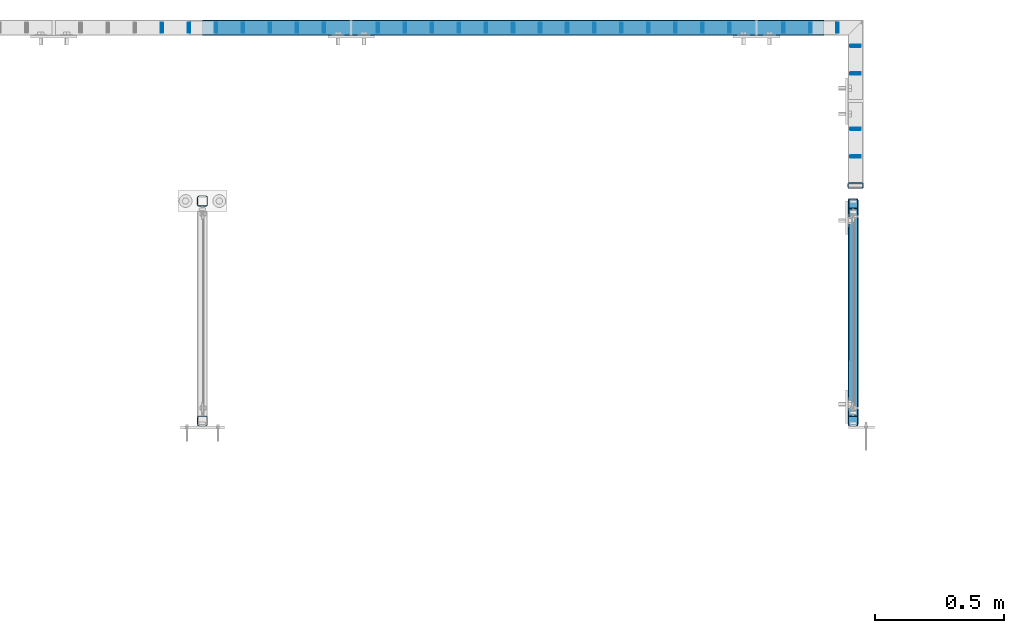
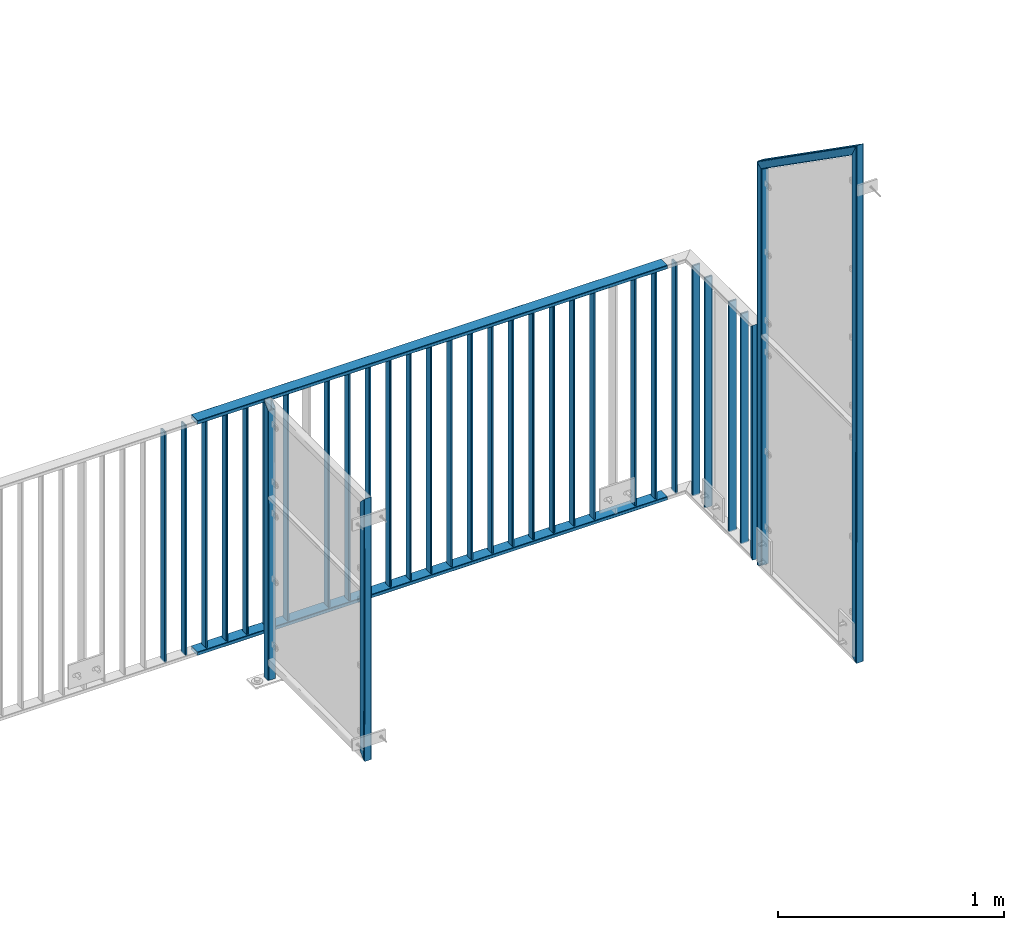
# One storey, part 24 of 156: 36 beams, 5 elements without a shape of their own.
"""IFC2X3 building model written with IfcOpenShell, lengths in millimetres."""

from ifc_helpers import new_model, si_unit, frame, origin_with_axes, origin_2d_with_axis, place, context, subcontext, project, spatial, hollow_rectangle, extrude, clip, halfspace, material, type_object, element, aggregate, save


model = new_model("IFC2X3")

# Units and contexts
model_context = context("Model", 3, precision=1e-05, world=origin_with_axes())
body_context = subcontext(model_context, "Body", "Model", "MODEL_VIEW")
ifc_project = project(units=[si_unit("LENGTHUNIT", "METRE", prefix="MILLI"), si_unit("AREAUNIT", "SQUARE_METRE"), si_unit("VOLUMEUNIT", "CUBIC_METRE"), si_unit("MASSUNIT", "GRAM", prefix="KILO"), si_unit("TIMEUNIT", "SECOND"), si_unit("PLANEANGLEUNIT", "RADIAN"), si_unit("SOLIDANGLEUNIT", "STERADIAN"), si_unit("THERMODYNAMICTEMPERATUREUNIT", "DEGREE_CELSIUS"), si_unit("LUMINOUSINTENSITYUNIT", "LUMEN")], contexts=[model_context])

# Site, building, storey
site_placement = place(None, origin_with_axes())
site = spatial("IfcSite", under=ifc_project, at=site_placement, CompositionType="ELEMENT")
building_placement = place(site_placement, origin_with_axes())
building = spatial("IfcBuilding", under=site, at=building_placement, Name="Undefined", CompositionType="ELEMENT")
storey_placement = place(building_placement, origin_with_axes())
storey = spatial("IfcBuildingStorey", under=building, at=storey_placement, Name="Undefined", CompositionType="ELEMENT", Elevation=0.0)

# Assembly, beam
assembly_1_placement = place(storey_placement, origin_with_axes())
assembly_1 = element("IfcElementAssembly", 1, at=assembly_1_placement, inside=storey, AssemblyPlace="NOTDEFINED", PredefinedType="RIGID_FRAME")
ifc_material = material(Name="STEEL/S235JR")
beam_type_1 = type_object("IfcBeamType", Name="K60/20/2", PredefinedType="NOTDEFINED")
beam_1_placement = place(assembly_1_placement, frame((26802.6741455078, 24057.9916132584, 2740.0), z_axis=(0.0, -1.0, 0.0), x_axis=(-1.0, 0.0, 0.0)))
beam_1 = element("IfcBeam", 2, at=beam_1_placement, type_object=beam_type_1, material=ifc_material, ObjectType="K60/20/2", context=body_context, shape_type="SweptSolid", body=[
    extrude(hollow_rectangle(XDim=20.0, YDim=60.0, WallThickness=2.0, InnerFilletRadius=2.0, OuterFilletRadius=4.0, at=origin_2d_with_axis()), frame((2402.72054931641, 0.0, 0.0), z_axis=(-1.0, 0.0, 0.0), x_axis=(0.0, -1.0, 0.0)), (0.0, 0.0, 1.0), 2402.72),
])

assembly_2_placement = place(storey_placement, origin_with_axes())
assembly_2 = element("IfcElementAssembly", 3, at=assembly_2_placement, inside=storey, AssemblyPlace="NOTDEFINED", PredefinedType="RIGID_FRAME")
beam_2_placement = place(assembly_2_placement, frame((26924.9961242676, 23448.0012658527, 4000.0), z_axis=(-1.0, 0.0, 0.0), x_axis=(0.0, 0.0, -1.0)))
beam_2 = element("IfcBeam", 4, at=beam_2_placement, type_object=beam_type_1, material=ifc_material, ObjectType="K60/20/2", context=body_context, shape_type="Clipping", body=[
    clip(clip(extrude(hollow_rectangle(XDim=20.0, YDim=60.0, WallThickness=2.0, InnerFilletRadius=2.0, OuterFilletRadius=4.0, at=origin_2d_with_axis()), frame((1280.2, 0.0, 0.0), z_axis=(-1.0, 0.0, 0.0), x_axis=(0.0, -1.0, 0.0)), (0.0, 0.0, 1.0), 1290.4), halfspace(frame((1270.0, 10.0, 0.0), z_axis=(0.707106781186548, -0.707106781186548, 0.0), x_axis=(0.0, 0.0, -1.0)), False)), halfspace(frame((20.0, -10.0, 0.0), z_axis=(-0.707106781186548, -0.707106781186548, 0.0), x_axis=(0.0, 0.0, -1.0)), False)),
])

# Beam
beam_3_placement = place(assembly_1_placement, frame((26802.6741455078, 24057.9916132584, 3990.0), z_axis=(0.0, -1.0, 0.0), x_axis=(-1.0, 0.0, 0.0)))
beam_3 = element("IfcBeam", 5, at=beam_3_placement, type_object=beam_type_1, material=ifc_material, ObjectType="K60/20/2", context=body_context, shape_type="SweptSolid", body=[
    extrude(hollow_rectangle(XDim=20.0, YDim=60.0, WallThickness=2.0, InnerFilletRadius=2.0, OuterFilletRadius=4.0, at=origin_2d_with_axis()), frame((2402.72054931641, 0.0, 0.0), z_axis=(-1.0, 0.0, 0.0), x_axis=(0.0, -1.0, 0.0)), (0.0, 0.0, 1.0), 2402.72),
])

beam_type_2 = type_object("IfcBeamType", Name="K40/10/1.5", PredefinedType="NOTDEFINED")
beam_4_placement = place(assembly_1_placement, frame((25079.0085961914, 24057.9916132584, 3980.00000000003), z_axis=(0.0, -1.0, 0.0), x_axis=(0.0, 0.0, -1.0)))
beam_4 = element("IfcBeam", 6, at=beam_4_placement, type_object=beam_type_2, material=ifc_material, ObjectType="K40/10/1.5", context=body_context, shape_type="Clipping", body=[
    clip(clip(extrude(hollow_rectangle(XDim=10.0, YDim=40.0, WallThickness=1.5, InnerFilletRadius=1.5, OuterFilletRadius=3.0, at=origin_2d_with_axis()), frame((1237.00000000003, 0.0, 0.0), z_axis=(-1.0, 0.0, 0.0), x_axis=(0.0, -1.0, 0.0)), (0.0, 0.0, 1.0), 1244.0), halfspace(frame((1237.00000000003, 4.34248751949781, 47.3810900558092), z_axis=(1.0, 0.0, 0.0), x_axis=(0.0, -0.768354814194188, -0.640024124158313)), False)), halfspace(frame((-6.99999999997453, -4.34248751950508, 47.3810900558092), z_axis=(-1.0, 0.0, 0.0), x_axis=(0.0, 0.7683548141934, -0.640024124159258)), False)),
])

beam_5_placement = place(assembly_1_placement, frame((26646.0585961914, 24057.9916132584, 3980.00000000003), z_axis=(0.0, -1.0, 0.0), x_axis=(0.0, 0.0, -1.0)))
beam_5 = element("IfcBeam", 7, at=beam_5_placement, type_object=beam_type_2, material=ifc_material, ObjectType="K40/10/1.5", context=body_context, shape_type="Clipping", body=[
    clip(clip(extrude(hollow_rectangle(XDim=10.0, YDim=40.0, WallThickness=1.5, InnerFilletRadius=1.5, OuterFilletRadius=3.0, at=origin_2d_with_axis()), frame((1237.00000000003, 0.0, 0.0), z_axis=(-1.0, 0.0, 0.0), x_axis=(0.0, -1.0, 0.0)), (0.0, 0.0, 1.0), 1244.0), halfspace(frame((1237.00000000003, 4.34248751949781, 47.3810900558092), z_axis=(1.0, 0.0, 0.0), x_axis=(0.0, -0.768354814194188, -0.640024124158313)), False)), halfspace(frame((-6.99999999997453, -4.34248751950508, 47.3810900558092), z_axis=(-1.0, 0.0, 0.0), x_axis=(0.0, 0.7683548141934, -0.640024124159258)), False)),
])

# Assembly, beams
assembly_3_placement = place(storey_placement, origin_with_axes())
assembly_3 = element("IfcElementAssembly", 8, at=assembly_3_placement, inside=storey, AssemblyPlace="NOTDEFINED", PredefinedType="RIGID_FRAME")
beam_6_placement = place(assembly_3_placement, frame((24243.2485961914, 24057.9916132584, 3980.00000000003), z_axis=(0.0, -1.0, 0.0), x_axis=(0.0, 0.0, -1.0)))
beam_6 = element("IfcBeam", 9, at=beam_6_placement, type_object=beam_type_2, material=ifc_material, ObjectType="K40/10/1.5", context=body_context, shape_type="Clipping", body=[
    clip(clip(extrude(hollow_rectangle(XDim=10.0, YDim=40.0, WallThickness=1.5, InnerFilletRadius=1.5, OuterFilletRadius=3.0, at=origin_2d_with_axis()), frame((1237.00000000003, 0.0, 0.0), z_axis=(-1.0, 0.0, 0.0), x_axis=(0.0, -1.0, 0.0)), (0.0, 0.0, 1.0), 1244.0), halfspace(frame((1237.00000000003, 4.34248751949781, 47.3810900558092), z_axis=(1.0, 0.0, 0.0), x_axis=(0.0, -0.768354814194188, -0.640024124158313)), False)), halfspace(frame((-6.99999999997453, -4.34248751950508, 47.3810900558092), z_axis=(-1.0, 0.0, 0.0), x_axis=(0.0, 0.7683548141934, -0.640024124159258)), False)),
])
beam_7_placement = place(assembly_3_placement, frame((24347.7185961914, 24057.9916132584, 3980.00000000003), z_axis=(0.0, -1.0, 0.0), x_axis=(0.0, 0.0, -1.0)))
beam_7 = element("IfcBeam", 10, at=beam_7_placement, type_object=beam_type_2, material=ifc_material, ObjectType="K40/10/1.5", context=body_context, shape_type="Clipping", body=[
    clip(clip(extrude(hollow_rectangle(XDim=10.0, YDim=40.0, WallThickness=1.5, InnerFilletRadius=1.5, OuterFilletRadius=3.0, at=origin_2d_with_axis()), frame((1237.00000000003, 0.0, 0.0), z_axis=(-1.0, 0.0, 0.0), x_axis=(0.0, -1.0, 0.0)), (0.0, 0.0, 1.0), 1244.0), halfspace(frame((1237.00000000003, 4.34248751949781, 47.3810900558092), z_axis=(1.0, 0.0, 0.0), x_axis=(0.0, -0.768354814194188, -0.640024124158313)), False)), halfspace(frame((-6.99999999997453, -4.34248751950508, 47.3810900558092), z_axis=(-1.0, 0.0, 0.0), x_axis=(0.0, 0.7683548141934, -0.640024124159258)), False)),
])
aggregate(assembly_3, [beam_6, beam_7])

# Beam
beam_8_placement = place(assembly_1_placement, frame((24452.1885961914, 24057.9916132584, 3980.00000000003), z_axis=(0.0, -1.0, 0.0), x_axis=(0.0, 0.0, -1.0)))
beam_8 = element("IfcBeam", 11, at=beam_8_placement, type_object=beam_type_2, material=ifc_material, ObjectType="K40/10/1.5", context=body_context, shape_type="Clipping", body=[
    clip(clip(extrude(hollow_rectangle(XDim=10.0, YDim=40.0, WallThickness=1.5, InnerFilletRadius=1.5, OuterFilletRadius=3.0, at=origin_2d_with_axis()), frame((1237.00000000003, 0.0, 0.0), z_axis=(-1.0, 0.0, 0.0), x_axis=(0.0, -1.0, 0.0)), (0.0, 0.0, 1.0), 1244.0), halfspace(frame((1237.00000000003, 4.34248751949781, 47.3810900558092), z_axis=(1.0, 0.0, 0.0), x_axis=(0.0, -0.768354814194188, -0.640024124158313)), False)), halfspace(frame((-6.99999999997453, -4.34248751950508, 47.3810900558092), z_axis=(-1.0, 0.0, 0.0), x_axis=(0.0, 0.7683548141934, -0.640024124159258)), False)),
])

beam_9_placement = place(assembly_1_placement, frame((24556.6585961914, 24057.9916132584, 3980.00000000003), z_axis=(0.0, -1.0, 0.0), x_axis=(0.0, 0.0, -1.0)))
beam_9 = element("IfcBeam", 12, at=beam_9_placement, type_object=beam_type_2, material=ifc_material, ObjectType="K40/10/1.5", context=body_context, shape_type="Clipping", body=[
    clip(clip(extrude(hollow_rectangle(XDim=10.0, YDim=40.0, WallThickness=1.5, InnerFilletRadius=1.5, OuterFilletRadius=3.0, at=origin_2d_with_axis()), frame((1237.00000000003, 0.0, 0.0), z_axis=(-1.0, 0.0, 0.0), x_axis=(0.0, -1.0, 0.0)), (0.0, 0.0, 1.0), 1244.0), halfspace(frame((1237.00000000003, 4.34248751949781, 47.3810900558092), z_axis=(1.0, 0.0, 0.0), x_axis=(0.0, -0.768354814194188, -0.640024124158313)), False)), halfspace(frame((-6.99999999997453, -4.34248751950508, 47.3810900558092), z_axis=(-1.0, 0.0, 0.0), x_axis=(0.0, 0.7683548141934, -0.640024124159258)), False)),
])

beam_10_placement = place(assembly_1_placement, frame((24661.1285961914, 24057.9916132584, 3980.00000000003), z_axis=(0.0, -1.0, 0.0), x_axis=(0.0, 0.0, -1.0)))
beam_10 = element("IfcBeam", 13, at=beam_10_placement, type_object=beam_type_2, material=ifc_material, ObjectType="K40/10/1.5", context=body_context, shape_type="Clipping", body=[
    clip(clip(extrude(hollow_rectangle(XDim=10.0, YDim=40.0, WallThickness=1.5, InnerFilletRadius=1.5, OuterFilletRadius=3.0, at=origin_2d_with_axis()), frame((1237.00000000003, 0.0, 0.0), z_axis=(-1.0, 0.0, 0.0), x_axis=(0.0, -1.0, 0.0)), (0.0, 0.0, 1.0), 1244.0), halfspace(frame((1237.00000000003, 4.34248751949781, 47.3810900558092), z_axis=(1.0, 0.0, 0.0), x_axis=(0.0, -0.768354814194188, -0.640024124158313)), False)), halfspace(frame((-6.99999999997453, -4.34248751950508, 47.3810900558092), z_axis=(-1.0, 0.0, 0.0), x_axis=(0.0, 0.7683548141934, -0.640024124159258)), False)),
])

beam_11_placement = place(assembly_1_placement, frame((24765.5985961914, 24057.9916132584, 3980.00000000003), z_axis=(0.0, -1.0, 0.0), x_axis=(0.0, 0.0, -1.0)))
beam_11 = element("IfcBeam", 14, at=beam_11_placement, type_object=beam_type_2, material=ifc_material, ObjectType="K40/10/1.5", context=body_context, shape_type="Clipping", body=[
    clip(clip(extrude(hollow_rectangle(XDim=10.0, YDim=40.0, WallThickness=1.5, InnerFilletRadius=1.5, OuterFilletRadius=3.0, at=origin_2d_with_axis()), frame((1237.00000000003, 0.0, 0.0), z_axis=(-1.0, 0.0, 0.0), x_axis=(0.0, -1.0, 0.0)), (0.0, 0.0, 1.0), 1244.0), halfspace(frame((1237.00000000003, 4.34248751949781, 47.3810900558092), z_axis=(1.0, 0.0, 0.0), x_axis=(0.0, -0.768354814194188, -0.640024124158313)), False)), halfspace(frame((-6.99999999997453, -4.34248751950508, 47.3810900558092), z_axis=(-1.0, 0.0, 0.0), x_axis=(0.0, 0.7683548141934, -0.640024124159258)), False)),
])

beam_12_placement = place(assembly_1_placement, frame((24870.0685961914, 24057.9916132584, 3980.00000000003), z_axis=(0.0, -1.0, 0.0), x_axis=(0.0, 0.0, -1.0)))
beam_12 = element("IfcBeam", 15, at=beam_12_placement, type_object=beam_type_2, material=ifc_material, ObjectType="K40/10/1.5", context=body_context, shape_type="Clipping", body=[
    clip(clip(extrude(hollow_rectangle(XDim=10.0, YDim=40.0, WallThickness=1.5, InnerFilletRadius=1.5, OuterFilletRadius=3.0, at=origin_2d_with_axis()), frame((1237.00000000003, 0.0, 0.0), z_axis=(-1.0, 0.0, 0.0), x_axis=(0.0, -1.0, 0.0)), (0.0, 0.0, 1.0), 1244.0), halfspace(frame((1237.00000000003, 4.34248751949781, 47.3810900558092), z_axis=(1.0, 0.0, 0.0), x_axis=(0.0, -0.768354814194188, -0.640024124158313)), False)), halfspace(frame((-6.99999999997453, -4.34248751950508, 47.3810900558092), z_axis=(-1.0, 0.0, 0.0), x_axis=(0.0, 0.7683548141934, -0.640024124159258)), False)),
])

beam_13_placement = place(assembly_1_placement, frame((25183.4785961914, 24057.9916132584, 3980.00000000003), z_axis=(0.0, -1.0, 0.0), x_axis=(0.0, 0.0, -1.0)))
beam_13 = element("IfcBeam", 16, at=beam_13_placement, type_object=beam_type_2, material=ifc_material, ObjectType="K40/10/1.5", context=body_context, shape_type="Clipping", body=[
    clip(clip(extrude(hollow_rectangle(XDim=10.0, YDim=40.0, WallThickness=1.5, InnerFilletRadius=1.5, OuterFilletRadius=3.0, at=origin_2d_with_axis()), frame((1237.00000000003, 0.0, 0.0), z_axis=(-1.0, 0.0, 0.0), x_axis=(0.0, -1.0, 0.0)), (0.0, 0.0, 1.0), 1244.0), halfspace(frame((1237.00000000003, 4.34248751949781, 47.3810900558092), z_axis=(1.0, 0.0, 0.0), x_axis=(0.0, -0.768354814194188, -0.640024124158313)), False)), halfspace(frame((-6.99999999997453, -4.34248751950508, 47.3810900558092), z_axis=(-1.0, 0.0, 0.0), x_axis=(0.0, 0.7683548141934, -0.640024124159258)), False)),
])

beam_14_placement = place(assembly_1_placement, frame((25287.9485961914, 24057.9916132584, 3980.00000000003), z_axis=(0.0, -1.0, 0.0), x_axis=(0.0, 0.0, -1.0)))
beam_14 = element("IfcBeam", 17, at=beam_14_placement, type_object=beam_type_2, material=ifc_material, ObjectType="K40/10/1.5", context=body_context, shape_type="Clipping", body=[
    clip(clip(extrude(hollow_rectangle(XDim=10.0, YDim=40.0, WallThickness=1.5, InnerFilletRadius=1.5, OuterFilletRadius=3.0, at=origin_2d_with_axis()), frame((1237.00000000003, 0.0, 0.0), z_axis=(-1.0, 0.0, 0.0), x_axis=(0.0, -1.0, 0.0)), (0.0, 0.0, 1.0), 1244.0), halfspace(frame((1237.00000000003, 4.34248751949781, 47.3810900558092), z_axis=(1.0, 0.0, 0.0), x_axis=(0.0, -0.768354814194188, -0.640024124158313)), False)), halfspace(frame((-6.99999999997453, -4.34248751950508, 47.3810900558092), z_axis=(-1.0, 0.0, 0.0), x_axis=(0.0, 0.7683548141934, -0.640024124159258)), False)),
])

beam_15_placement = place(assembly_1_placement, frame((25392.4185961914, 24057.9916132584, 3980.00000000003), z_axis=(0.0, -1.0, 0.0), x_axis=(0.0, 0.0, -1.0)))
beam_15 = element("IfcBeam", 18, at=beam_15_placement, type_object=beam_type_2, material=ifc_material, ObjectType="K40/10/1.5", context=body_context, shape_type="Clipping", body=[
    clip(clip(extrude(hollow_rectangle(XDim=10.0, YDim=40.0, WallThickness=1.5, InnerFilletRadius=1.5, OuterFilletRadius=3.0, at=origin_2d_with_axis()), frame((1237.00000000003, 0.0, 0.0), z_axis=(-1.0, 0.0, 0.0), x_axis=(0.0, -1.0, 0.0)), (0.0, 0.0, 1.0), 1244.0), halfspace(frame((1237.00000000003, 4.34248751949781, 47.3810900558092), z_axis=(1.0, 0.0, 0.0), x_axis=(0.0, -0.768354814194188, -0.640024124158313)), False)), halfspace(frame((-6.99999999997453, -4.34248751950508, 47.3810900558092), z_axis=(-1.0, 0.0, 0.0), x_axis=(0.0, 0.7683548141934, -0.640024124159258)), False)),
])

beam_16_placement = place(assembly_1_placement, frame((25496.8885961914, 24057.9916132584, 3980.00000000003), z_axis=(0.0, -1.0, 0.0), x_axis=(0.0, 0.0, -1.0)))
beam_16 = element("IfcBeam", 19, at=beam_16_placement, type_object=beam_type_2, material=ifc_material, ObjectType="K40/10/1.5", context=body_context, shape_type="Clipping", body=[
    clip(clip(extrude(hollow_rectangle(XDim=10.0, YDim=40.0, WallThickness=1.5, InnerFilletRadius=1.5, OuterFilletRadius=3.0, at=origin_2d_with_axis()), frame((1237.00000000003, 0.0, 0.0), z_axis=(-1.0, 0.0, 0.0), x_axis=(0.0, -1.0, 0.0)), (0.0, 0.0, 1.0), 1244.0), halfspace(frame((1237.00000000003, 4.34248751949781, 47.3810900558092), z_axis=(1.0, 0.0, 0.0), x_axis=(0.0, -0.768354814194188, -0.640024124158313)), False)), halfspace(frame((-6.99999999997453, -4.34248751950508, 47.3810900558092), z_axis=(-1.0, 0.0, 0.0), x_axis=(0.0, 0.7683548141934, -0.640024124159258)), False)),
])

beam_17_placement = place(assembly_1_placement, frame((25601.3585961914, 24057.9916132584, 3980.00000000003), z_axis=(0.0, -1.0, 0.0), x_axis=(0.0, 0.0, -1.0)))
beam_17 = element("IfcBeam", 20, at=beam_17_placement, type_object=beam_type_2, material=ifc_material, ObjectType="K40/10/1.5", context=body_context, shape_type="Clipping", body=[
    clip(clip(extrude(hollow_rectangle(XDim=10.0, YDim=40.0, WallThickness=1.5, InnerFilletRadius=1.5, OuterFilletRadius=3.0, at=origin_2d_with_axis()), frame((1237.00000000003, 0.0, 0.0), z_axis=(-1.0, 0.0, 0.0), x_axis=(0.0, -1.0, 0.0)), (0.0, 0.0, 1.0), 1244.0), halfspace(frame((1237.00000000003, 4.34248751949781, 47.3810900558092), z_axis=(1.0, 0.0, 0.0), x_axis=(0.0, -0.768354814194188, -0.640024124158313)), False)), halfspace(frame((-6.99999999997453, -4.34248751950508, 47.3810900558092), z_axis=(-1.0, 0.0, 0.0), x_axis=(0.0, 0.7683548141934, -0.640024124159258)), False)),
])

beam_18_placement = place(assembly_1_placement, frame((25705.8285961914, 24057.9916132584, 3980.00000000003), z_axis=(0.0, -1.0, 0.0), x_axis=(0.0, 0.0, -1.0)))
beam_18 = element("IfcBeam", 21, at=beam_18_placement, type_object=beam_type_2, material=ifc_material, ObjectType="K40/10/1.5", context=body_context, shape_type="Clipping", body=[
    clip(clip(extrude(hollow_rectangle(XDim=10.0, YDim=40.0, WallThickness=1.5, InnerFilletRadius=1.5, OuterFilletRadius=3.0, at=origin_2d_with_axis()), frame((1237.00000000003, 0.0, 0.0), z_axis=(-1.0, 0.0, 0.0), x_axis=(0.0, -1.0, 0.0)), (0.0, 0.0, 1.0), 1244.0), halfspace(frame((1237.00000000003, 4.34248751949781, 47.3810900558092), z_axis=(1.0, 0.0, 0.0), x_axis=(0.0, -0.768354814194188, -0.640024124158313)), False)), halfspace(frame((-6.99999999997453, -4.34248751950508, 47.3810900558092), z_axis=(-1.0, 0.0, 0.0), x_axis=(0.0, 0.7683548141934, -0.640024124159258)), False)),
])

beam_19_placement = place(assembly_1_placement, frame((25810.2985961914, 24057.9916132584, 3980.00000000003), z_axis=(0.0, -1.0, 0.0), x_axis=(0.0, 0.0, -1.0)))
beam_19 = element("IfcBeam", 22, at=beam_19_placement, type_object=beam_type_2, material=ifc_material, ObjectType="K40/10/1.5", context=body_context, shape_type="Clipping", body=[
    clip(clip(extrude(hollow_rectangle(XDim=10.0, YDim=40.0, WallThickness=1.5, InnerFilletRadius=1.5, OuterFilletRadius=3.0, at=origin_2d_with_axis()), frame((1237.00000000003, 0.0, 0.0), z_axis=(-1.0, 0.0, 0.0), x_axis=(0.0, -1.0, 0.0)), (0.0, 0.0, 1.0), 1244.0), halfspace(frame((1237.00000000003, 4.34248751949781, 47.3810900558092), z_axis=(1.0, 0.0, 0.0), x_axis=(0.0, -0.768354814194188, -0.640024124158313)), False)), halfspace(frame((-6.99999999997453, -4.34248751950508, 47.3810900558092), z_axis=(-1.0, 0.0, 0.0), x_axis=(0.0, 0.7683548141934, -0.640024124159258)), False)),
])

beam_20_placement = place(assembly_1_placement, frame((25914.7685961914, 24057.9916132584, 3980.00000000003), z_axis=(0.0, -1.0, 0.0), x_axis=(0.0, 0.0, -1.0)))
beam_20 = element("IfcBeam", 23, at=beam_20_placement, type_object=beam_type_2, material=ifc_material, ObjectType="K40/10/1.5", context=body_context, shape_type="Clipping", body=[
    clip(clip(extrude(hollow_rectangle(XDim=10.0, YDim=40.0, WallThickness=1.5, InnerFilletRadius=1.5, OuterFilletRadius=3.0, at=origin_2d_with_axis()), frame((1237.00000000003, 0.0, 0.0), z_axis=(-1.0, 0.0, 0.0), x_axis=(0.0, -1.0, 0.0)), (0.0, 0.0, 1.0), 1244.0), halfspace(frame((1237.00000000003, 4.34248751949781, 47.3810900558092), z_axis=(1.0, 0.0, 0.0), x_axis=(0.0, -0.768354814194188, -0.640024124158313)), False)), halfspace(frame((-6.99999999997453, -4.34248751950508, 47.3810900558092), z_axis=(-1.0, 0.0, 0.0), x_axis=(0.0, 0.7683548141934, -0.640024124159258)), False)),
])

beam_21_placement = place(assembly_1_placement, frame((26019.2385961914, 24057.9916132584, 3980.00000000003), z_axis=(0.0, -1.0, 0.0), x_axis=(0.0, 0.0, -1.0)))
beam_21 = element("IfcBeam", 24, at=beam_21_placement, type_object=beam_type_2, material=ifc_material, ObjectType="K40/10/1.5", context=body_context, shape_type="Clipping", body=[
    clip(clip(extrude(hollow_rectangle(XDim=10.0, YDim=40.0, WallThickness=1.5, InnerFilletRadius=1.5, OuterFilletRadius=3.0, at=origin_2d_with_axis()), frame((1237.00000000003, 0.0, 0.0), z_axis=(-1.0, 0.0, 0.0), x_axis=(0.0, -1.0, 0.0)), (0.0, 0.0, 1.0), 1244.0), halfspace(frame((1237.00000000003, 4.34248751949781, 47.3810900558092), z_axis=(1.0, 0.0, 0.0), x_axis=(0.0, -0.768354814194188, -0.640024124158313)), False)), halfspace(frame((-6.99999999997453, -4.34248751950508, 47.3810900558092), z_axis=(-1.0, 0.0, 0.0), x_axis=(0.0, 0.7683548141934, -0.640024124159258)), False)),
])

beam_22_placement = place(assembly_1_placement, frame((26123.7085961914, 24057.9916132584, 3980.00000000003), z_axis=(0.0, -1.0, 0.0), x_axis=(0.0, 0.0, -1.0)))
beam_22 = element("IfcBeam", 25, at=beam_22_placement, type_object=beam_type_2, material=ifc_material, ObjectType="K40/10/1.5", context=body_context, shape_type="Clipping", body=[
    clip(clip(extrude(hollow_rectangle(XDim=10.0, YDim=40.0, WallThickness=1.5, InnerFilletRadius=1.5, OuterFilletRadius=3.0, at=origin_2d_with_axis()), frame((1237.00000000003, 0.0, 0.0), z_axis=(-1.0, 0.0, 0.0), x_axis=(0.0, -1.0, 0.0)), (0.0, 0.0, 1.0), 1244.0), halfspace(frame((1237.00000000003, 4.34248751949781, 47.3810900558092), z_axis=(1.0, 0.0, 0.0), x_axis=(0.0, -0.768354814194188, -0.640024124158313)), False)), halfspace(frame((-6.99999999997453, -4.34248751950508, 47.3810900558092), z_axis=(-1.0, 0.0, 0.0), x_axis=(0.0, 0.7683548141934, -0.640024124159258)), False)),
])

beam_23_placement = place(assembly_1_placement, frame((26228.1785961914, 24057.9916132584, 3980.00000000003), z_axis=(0.0, -1.0, 0.0), x_axis=(0.0, 0.0, -1.0)))
beam_23 = element("IfcBeam", 26, at=beam_23_placement, type_object=beam_type_2, material=ifc_material, ObjectType="K40/10/1.5", context=body_context, shape_type="Clipping", body=[
    clip(clip(extrude(hollow_rectangle(XDim=10.0, YDim=40.0, WallThickness=1.5, InnerFilletRadius=1.5, OuterFilletRadius=3.0, at=origin_2d_with_axis()), frame((1237.00000000003, 0.0, 0.0), z_axis=(-1.0, 0.0, 0.0), x_axis=(0.0, -1.0, 0.0)), (0.0, 0.0, 1.0), 1244.0), halfspace(frame((1237.00000000003, 4.34248751949781, 47.3810900558092), z_axis=(1.0, 0.0, 0.0), x_axis=(0.0, -0.768354814194188, -0.640024124158313)), False)), halfspace(frame((-6.99999999997453, -4.34248751950508, 47.3810900558092), z_axis=(-1.0, 0.0, 0.0), x_axis=(0.0, 0.7683548141934, -0.640024124159258)), False)),
])

beam_24_placement = place(assembly_1_placement, frame((26332.6485961914, 24057.9916132584, 3980.00000000003), z_axis=(0.0, -1.0, 0.0), x_axis=(0.0, 0.0, -1.0)))
beam_24 = element("IfcBeam", 27, at=beam_24_placement, type_object=beam_type_2, material=ifc_material, ObjectType="K40/10/1.5", context=body_context, shape_type="Clipping", body=[
    clip(clip(extrude(hollow_rectangle(XDim=10.0, YDim=40.0, WallThickness=1.5, InnerFilletRadius=1.5, OuterFilletRadius=3.0, at=origin_2d_with_axis()), frame((1237.00000000003, 0.0, 0.0), z_axis=(-1.0, 0.0, 0.0), x_axis=(0.0, -1.0, 0.0)), (0.0, 0.0, 1.0), 1244.0), halfspace(frame((1237.00000000003, 4.34248751949781, 47.3810900558092), z_axis=(1.0, 0.0, 0.0), x_axis=(0.0, -0.768354814194188, -0.640024124158313)), False)), halfspace(frame((-6.99999999997453, -4.34248751950508, 47.3810900558092), z_axis=(-1.0, 0.0, 0.0), x_axis=(0.0, 0.7683548141934, -0.640024124159258)), False)),
])

beam_25_placement = place(assembly_1_placement, frame((26437.1185961914, 24057.9916132584, 3980.00000000003), z_axis=(0.0, -1.0, 0.0), x_axis=(0.0, 0.0, -1.0)))
beam_25 = element("IfcBeam", 28, at=beam_25_placement, type_object=beam_type_2, material=ifc_material, ObjectType="K40/10/1.5", context=body_context, shape_type="Clipping", body=[
    clip(clip(extrude(hollow_rectangle(XDim=10.0, YDim=40.0, WallThickness=1.5, InnerFilletRadius=1.5, OuterFilletRadius=3.0, at=origin_2d_with_axis()), frame((1237.00000000003, 0.0, 0.0), z_axis=(-1.0, 0.0, 0.0), x_axis=(0.0, -1.0, 0.0)), (0.0, 0.0, 1.0), 1244.0), halfspace(frame((1237.00000000003, 4.34248751949781, 47.3810900558092), z_axis=(1.0, 0.0, 0.0), x_axis=(0.0, -0.768354814194188, -0.640024124158313)), False)), halfspace(frame((-6.99999999997453, -4.34248751950508, 47.3810900558092), z_axis=(-1.0, 0.0, 0.0), x_axis=(0.0, 0.7683548141934, -0.640024124159258)), False)),
])

beam_26_placement = place(assembly_1_placement, frame((26750.5285961914, 24057.9916132584, 3980.00000000003), z_axis=(0.0, -1.0, 0.0), x_axis=(0.0, 0.0, -1.0)))
beam_26 = element("IfcBeam", 29, at=beam_26_placement, type_object=beam_type_2, material=ifc_material, ObjectType="K40/10/1.5", context=body_context, shape_type="Clipping", body=[
    clip(clip(extrude(hollow_rectangle(XDim=10.0, YDim=40.0, WallThickness=1.5, InnerFilletRadius=1.5, OuterFilletRadius=3.0, at=origin_2d_with_axis()), frame((1237.00000000003, 0.0, 0.0), z_axis=(-1.0, 0.0, 0.0), x_axis=(0.0, -1.0, 0.0)), (0.0, 0.0, 1.0), 1244.0), halfspace(frame((1237.00000000003, 4.28697690345871, 47.3348312091512), z_axis=(1.0, 0.0, 0.0), x_axis=(0.0, -0.763991285051099, -0.645226562043109)), False)), halfspace(frame((-6.99999999997453, -4.28697690345871, 47.3348312091512), z_axis=(-1.0, 0.0, 0.0), x_axis=(0.0, 0.763991285051099, -0.645226562043109)), False)),
])

aggregate(assembly_1, [beam_1, beam_4, beam_5, beam_8, beam_9, beam_10, beam_11, beam_12, beam_13, beam_14, beam_15, beam_16, beam_17, beam_18, beam_19, beam_20, beam_21, beam_22, beam_23, beam_24, beam_25, beam_26, beam_3])

beam_27_placement = place(assembly_2_placement, frame((26924.9982833167, 23560.3103835168, 3980.00000000003), z_axis=(-1.0, 0.0, 0.0), x_axis=(0.0, 0.0, -1.0)))
beam_27 = element("IfcBeam", 30, at=beam_27_placement, type_object=beam_type_2, material=ifc_material, ObjectType="K40/10/1.5", context=body_context, shape_type="Clipping", body=[
    clip(clip(extrude(hollow_rectangle(XDim=10.0, YDim=40.0, WallThickness=1.5, InnerFilletRadius=1.5, OuterFilletRadius=3.0, at=origin_2d_with_axis()), frame((1237.00000000003, 0.0, 0.0), z_axis=(-1.0, 0.0, 0.0), x_axis=(0.0, -1.0, 0.0)), (0.0, 0.0, 1.0), 1244.0), halfspace(frame((1237.00000000003, 3.63803898150218, 46.7940496082883), z_axis=(1.0, 0.0, 0.0), x_axis=(0.0, -0.758923924280425, -0.65117929724063)), False)), halfspace(frame((-6.99999999997453, -3.24498419219526, 46.4665039507308), z_axis=(-1.0, 0.0, 0.0), x_axis=(0.0, 0.75441426312288, -0.656398598106944)), False)),
])

beam_28_placement = place(assembly_2_placement, frame((26924.9982833167, 23667.2303835168, 3980.00000000003), z_axis=(-1.0, 0.0, 0.0), x_axis=(0.0, 0.0, -1.0)))
beam_28 = element("IfcBeam", 31, at=beam_28_placement, type_object=beam_type_2, material=ifc_material, ObjectType="K40/10/1.5", context=body_context, shape_type="Clipping", body=[
    clip(clip(extrude(hollow_rectangle(XDim=10.0, YDim=40.0, WallThickness=1.5, InnerFilletRadius=1.5, OuterFilletRadius=3.0, at=origin_2d_with_axis()), frame((1237.00000000003, 0.0, 0.0), z_axis=(-1.0, 0.0, 0.0), x_axis=(0.0, -1.0, 0.0)), (0.0, 0.0, 1.0), 1244.0), halfspace(frame((1237.00000000003, 3.2449841921989, 46.4665039507236), z_axis=(1.0, 0.0, 0.0), x_axis=(0.0, -0.754414263122933, -0.656398598106883)), False)), halfspace(frame((-6.99999999997453, -3.24498419219526, 46.4665039507308), z_axis=(-1.0, 0.0, 0.0), x_axis=(0.0, 0.75441426312288, -0.656398598106944)), False)),
])

beam_29_placement = place(assembly_2_placement, frame((26924.9982833167, 23881.0703835168, 3980.00000000003), z_axis=(-1.0, 0.0, 0.0), x_axis=(0.0, 0.0, -1.0)))
beam_29 = element("IfcBeam", 32, at=beam_29_placement, type_object=beam_type_2, material=ifc_material, ObjectType="K40/10/1.5", context=body_context, shape_type="Clipping", body=[
    clip(clip(extrude(hollow_rectangle(XDim=10.0, YDim=40.0, WallThickness=1.5, InnerFilletRadius=1.5, OuterFilletRadius=3.0, at=origin_2d_with_axis()), frame((1237.00000000003, 0.0, 0.0), z_axis=(-1.0, 0.0, 0.0), x_axis=(0.0, -1.0, 0.0)), (0.0, 0.0, 1.0), 1244.0), halfspace(frame((1237.00000000003, 3.2449841921989, 46.4665039507236), z_axis=(1.0, 0.0, 0.0), x_axis=(0.0, -0.754414263122933, -0.656398598106883)), False)), halfspace(frame((-6.99999999997453, -3.24498419219526, 46.4665039507308), z_axis=(-1.0, 0.0, 0.0), x_axis=(0.0, 0.75441426312288, -0.656398598106944)), False)),
])

beam_30_placement = place(assembly_2_placement, frame((26854.9985961914, 24057.9916132584, 3980.00000000003), z_axis=(0.0, -1.0, 0.0), x_axis=(0.0, 0.0, -1.0)))
beam_30 = element("IfcBeam", 33, at=beam_30_placement, type_object=beam_type_2, material=ifc_material, ObjectType="K40/10/1.5", context=body_context, shape_type="Clipping", body=[
    clip(clip(extrude(hollow_rectangle(XDim=10.0, YDim=40.0, WallThickness=1.5, InnerFilletRadius=1.5, OuterFilletRadius=3.0, at=origin_2d_with_axis()), frame((1237.00000000003, 0.0, 0.0), z_axis=(-1.0, 0.0, 0.0), x_axis=(0.0, -1.0, 0.0)), (0.0, 0.0, 1.0), 1244.0), halfspace(frame((1237.00000000003, 4.34248751949781, 47.3810900558092), z_axis=(1.0, 0.0, 0.0), x_axis=(0.0, -0.766598961667631, -0.642126180723158)), False)), halfspace(frame((-6.99999999997453, -4.34248751950508, 47.3810900558092), z_axis=(-1.0, 0.0, 0.0), x_axis=(0.0, 0.766598961668776, -0.642126180721792)), False)),
])

beam_31_placement = place(assembly_2_placement, frame((26924.9982833167, 23987.9903835168, 3980.00000000003), z_axis=(-1.0, 0.0, 0.0), x_axis=(0.0, 0.0, -1.0)))
beam_31 = element("IfcBeam", 34, at=beam_31_placement, type_object=beam_type_2, material=ifc_material, ObjectType="K40/10/1.5", context=body_context, shape_type="Clipping", body=[
    clip(clip(extrude(hollow_rectangle(XDim=10.0, YDim=40.0, WallThickness=1.5, InnerFilletRadius=1.5, OuterFilletRadius=3.0, at=origin_2d_with_axis()), frame((1237.00000000003, 0.0, 0.0), z_axis=(-1.0, 0.0, 0.0), x_axis=(0.0, -1.0, 0.0)), (0.0, 0.0, 1.0), 1244.0), halfspace(frame((1237.00000000003, 2.66359292875859, 45.9820112315028), z_axis=(1.0, 0.0, 0.0), x_axis=(0.0, -0.747680594278991, -0.664058528247785)), False)), halfspace(frame((-6.99999999997453, -2.66359292875859, 45.9820112315028), z_axis=(-1.0, 0.0, 0.0), x_axis=(0.0, 0.747680594279002, -0.664058528247773)), False)),
])

aggregate(assembly_2, [beam_27, beam_28, beam_29, beam_30, beam_2, beam_31])

# Assembly, beam
assembly_4_placement = place(storey_placement, origin_with_axes())
assembly_4 = element("IfcElementAssembly", 35, at=assembly_4_placement, inside=storey, AssemblyPlace="NOTDEFINED", PredefinedType="RIGID_FRAME")
beam_type_3 = type_object("IfcBeamType", Name="K40/3", PredefinedType="NOTDEFINED")
beam_32_placement = place(assembly_4_placement, frame((24400.0, 23388.0025791195, 4299.99608012897), z_axis=(1.0, 0.0, 0.0), x_axis=(0.0, 0.000195990999960296, -0.999999980793764)))
beam_32 = element("IfcBeam", 36, at=beam_32_placement, type_object=beam_type_3, material=ifc_material, ObjectType="K40/3", context=body_context, shape_type="Clipping", body=[
    clip(clip(extrude(hollow_rectangle(XDim=40.0, YDim=40.0, WallThickness=3.0, InnerFilletRadius=3.0, OuterFilletRadius=6.0, at=origin_2d_with_axis()), frame((1317.21220694614, 0.0, 0.0), z_axis=(-1.0, 0.0, 0.0), x_axis=(0.0, -1.0, 0.0)), (0.0, 0.0, 1.0), 1517.43), halfspace(frame((1297.00033107046, -3.63797880709171e-12, -20.0), z_axis=(-1.0, 0.0, 0.0), x_axis=(0.0, 1.0, 0.0)), True)), halfspace(frame((-200.000003844783, 19.9999999999418, 0.0), z_axis=(0.707176071357089, 0.70703748422552, 0.0), x_axis=(0.0, 0.0, -1.0)), True)),
])

# Assembly, beams
assembly_5_placement = place(storey_placement, origin_with_axes())
assembly_5 = element("IfcElementAssembly", 37, at=assembly_5_placement, inside=storey, AssemblyPlace="NOTDEFINED", PredefinedType="RIGID_FRAME")
beam_33_placement = place(assembly_5_placement, frame((26914.9961242676, 22496.5318112932, 5520.15365547741), z_axis=(0.0, 0.573576519196191, 0.819151986280191), x_axis=(0.0, 0.81915198628019, -0.573576519196192)))
beam_33 = element("IfcBeam", 38, at=beam_33_placement, type_object=beam_type_3, material=ifc_material, ObjectType="K40/3", context=body_context, shape_type="Clipping", body=[
    clip(clip(extrude(hollow_rectangle(XDim=40.0, YDim=40.0, WallThickness=3.0, InnerFilletRadius=3.0, OuterFilletRadius=6.0, at=origin_2d_with_axis()), frame((1137.4595634918, 0.0, 0.0), z_axis=(-1.0, 0.0, 0.0), x_axis=(0.0, -1.0, 0.0)), (0.0, 0.0, 1.0), 1148.21), halfspace(frame((1086.4887579936, 0.0, 20.0000000033942), z_axis=(0.887011256109767, 0.0, -0.461747800790186), x_axis=(0.0, 1.0, 0.0)), False)), halfspace(frame((12.2077467483559, 0.0, 20.0000000013606), z_axis=(0.461748568874198, 0.0, 0.88701085627101), x_axis=(0.0, 1.0, 0.0)), True)),
])
beam_34_placement = place(assembly_5_placement, frame((26914.9961242676, 22538.0033416748, 5505.42577206617), z_axis=(1.0, 0.0, 0.0), x_axis=(0.0, 0.0, -1.0)))
beam_34 = element("IfcBeam", 39, at=beam_34_placement, type_object=beam_type_3, material=ifc_material, ObjectType="K40/3", context=body_context, shape_type="Clipping", body=[
    clip(clip(extrude(hollow_rectangle(XDim=40.0, YDim=40.0, WallThickness=3.0, InnerFilletRadius=3.0, OuterFilletRadius=6.0, at=origin_2d_with_axis()), frame((2814.3296158744, 0.0, 0.0), z_axis=(-1.0, 0.0, 0.0), x_axis=(0.0, -1.0, 0.0)), (0.0, 0.0, 1.0), 2848.92), halfspace(frame((2775.42577206617, -20.0, 0.0), z_axis=(0.894427191199917, 0.447213595099955, 0.0), x_axis=(0.0, 0.0, 1.0)), False)), halfspace(frame((-24.1088462508069, -20.0, 0.0), z_axis=(-0.461748567887819, 0.887010856784486, 0.0), x_axis=(0.0, 0.0, -1.0)), False)),
])

# Beam
beam_35_placement = place(assembly_4_placement, frame((24400.0, 22538.0010528564, 4299.9999999525), z_axis=(1.0, 0.0, 0.0), x_axis=(0.0, 0.0, -1.0)))
beam_35 = element("IfcBeam", 40, at=beam_35_placement, type_object=beam_type_3, material=ifc_material, ObjectType="K40/3", context=body_context, shape_type="Clipping", body=[
    clip(clip(extrude(hollow_rectangle(XDim=40.0, YDim=40.0, WallThickness=3.0, InnerFilletRadius=3.0, OuterFilletRadius=6.0, at=origin_2d_with_axis()), frame((1240.4, 0.0, 0.0), z_axis=(-1.0, 0.0, 0.0), x_axis=(0.0, -1.0, 0.0)), (0.0, 0.0, 1.0), 1460.8), halfspace(frame((1180.0, 20.0, 0.0), z_axis=(-0.707106781186548, -0.707106781186548, 0.0), x_axis=(0.0, 0.0, 1.0)), True)), halfspace(frame((-200.0, -20.0, 0.0), z_axis=(0.707106781186548, -0.707106781186548, 0.0), x_axis=(0.0, 0.0, 1.0)), True)),
])

aggregate(assembly_4, [beam_32, beam_35])

beam_36_placement = place(assembly_5_placement, frame((26914.9961242676, 23378.0027312406, 4933.35224486177), z_axis=(1.0, 0.0, 0.0), x_axis=(0.0, 1.73100000029081e-06, -0.999999999998502)))
beam_36 = element("IfcBeam", 41, at=beam_36_placement, type_object=beam_type_3, material=ifc_material, ObjectType="K40/3", context=body_context, shape_type="Clipping", body=[
    clip(clip(extrude(hollow_rectangle(XDim=40.0, YDim=40.0, WallThickness=3.0, InnerFilletRadius=3.0, OuterFilletRadius=6.0, at=origin_2d_with_axis()), frame((2213.96778066274, 0.0, 0.0), z_axis=(-1.0, 0.0, 0.0), x_axis=(0.0, -1.0, 0.0)), (0.0, 0.0, 1.0), 2204.17), halfspace(frame((2183.35221024504, -19.999999997337, 0.0), z_axis=(-0.894426571672334, 0.447214834152978, 0.0), x_axis=(0.0, 0.0, -1.0)), True)), halfspace(frame((20.000024231771, 20.00000000004, 0.0), z_axis=(0.887011256231877, 0.461747800555614, 0.0), x_axis=(0.0, 0.0, -1.0)), True)),
])

aggregate(assembly_5, [beam_33, beam_34, beam_36])

save(model, "model.ifc")
